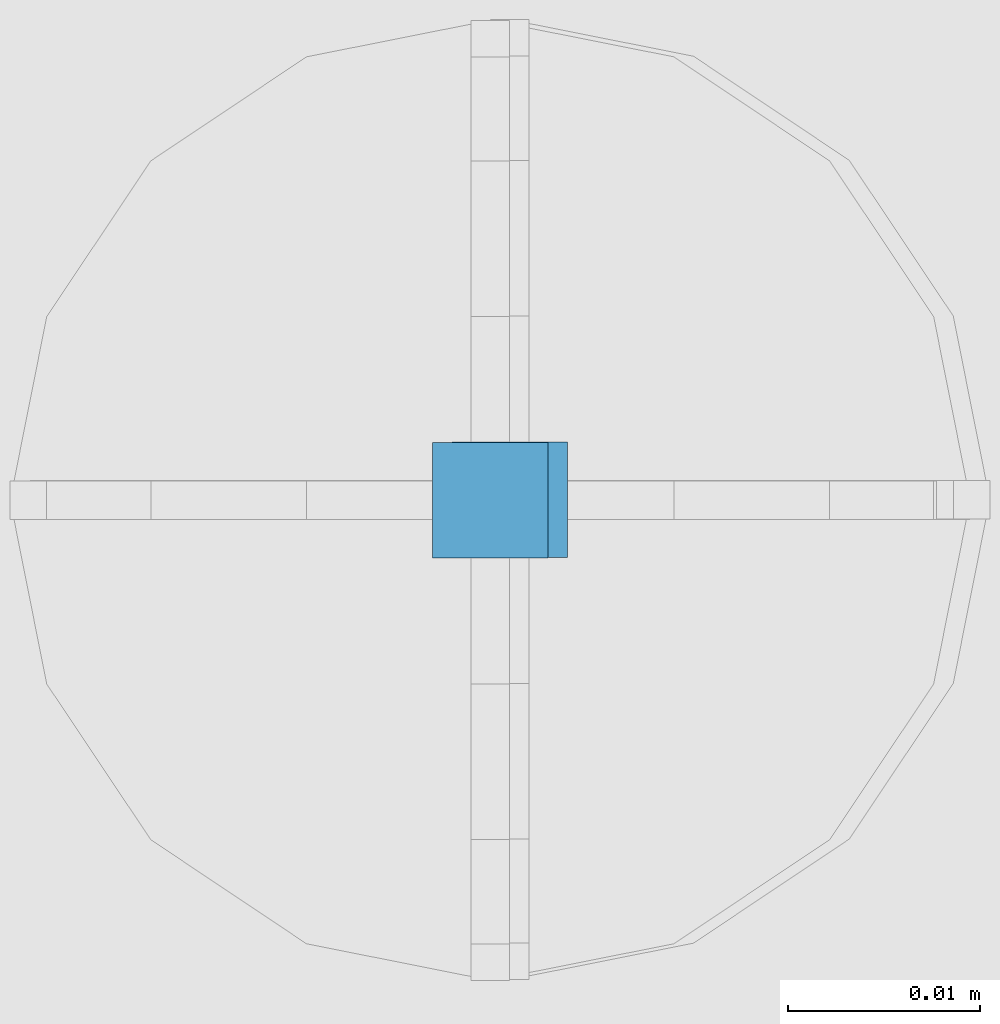
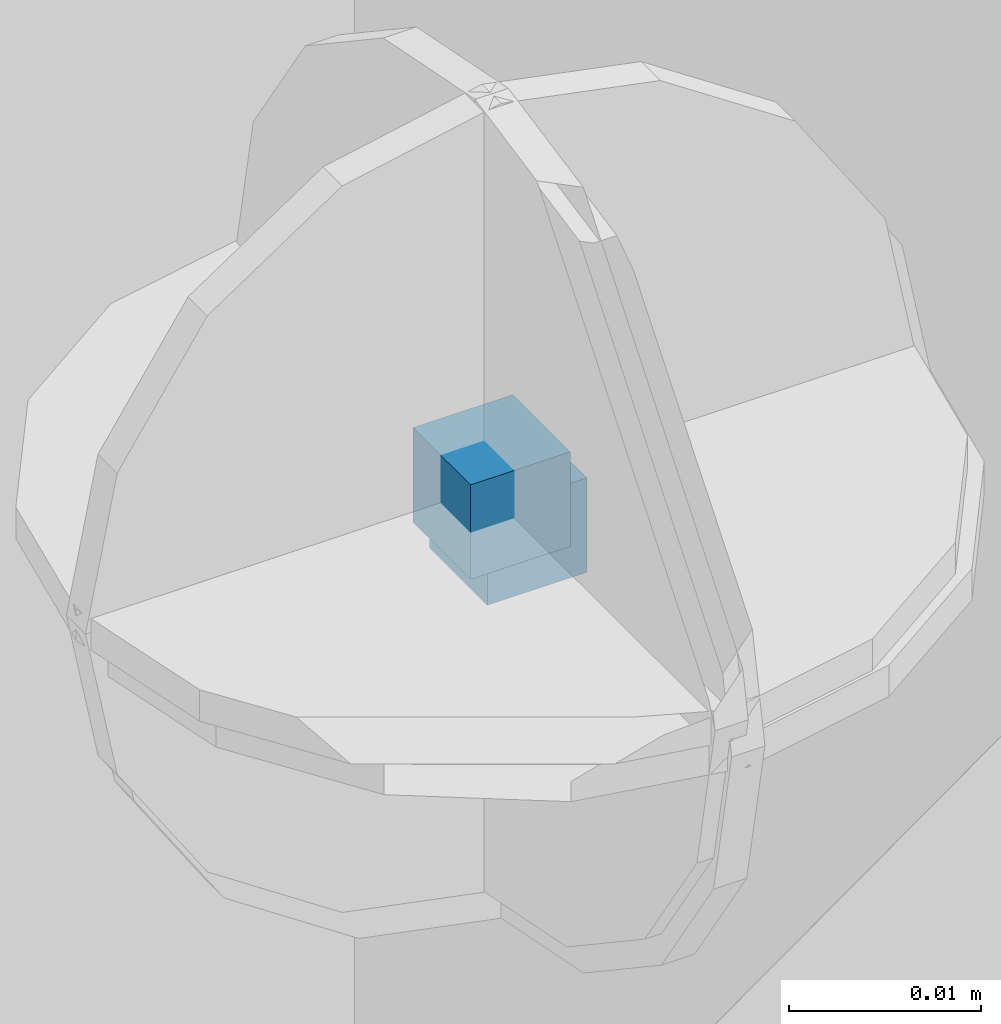
# One storey, part 73 of 341: 2 columns, 3 elements without a shape of their own.
"""IFC2X3 building model written with IfcOpenShell, lengths in millimetres."""

from ifc_helpers import new_model, si_unit, frame, origin_with_axes, place, context, subcontext, project, spatial, faceted_brep, material, type_object, element, aggregate, save


model = new_model("IFC2X3")

# Units and contexts
model_context = context("Model", 3, precision=1e-05, world=origin_with_axes())
body_context = subcontext(model_context, "Body", "Model", "MODEL_VIEW")
ifc_project = project(units=[si_unit("LENGTHUNIT", "METRE", prefix="MILLI"), si_unit("AREAUNIT", "SQUARE_METRE"), si_unit("VOLUMEUNIT", "CUBIC_METRE"), si_unit("MASSUNIT", "GRAM", prefix="KILO"), si_unit("TIMEUNIT", "SECOND"), si_unit("PLANEANGLEUNIT", "RADIAN"), si_unit("SOLIDANGLEUNIT", "STERADIAN"), si_unit("THERMODYNAMICTEMPERATUREUNIT", "DEGREE_CELSIUS"), si_unit("LUMINOUSINTENSITYUNIT", "LUMEN")], contexts=[model_context])

# Site, building, storey
site_placement = place(None, origin_with_axes())
site = spatial("IfcSite", under=ifc_project, at=site_placement, CompositionType="ELEMENT")
building_placement = place(site_placement, origin_with_axes())
building = spatial("IfcBuilding", under=site, at=building_placement, CompositionType="ELEMENT")
storey_placement = place(building_placement, origin_with_axes())
storey = spatial("IfcBuildingStorey", under=building, at=storey_placement, Name="5", CompositionType="ELEMENT", Elevation=0.0)

# Assemblies, columns
assembly_1_placement = place(storey_placement, origin_with_axes())
assembly_1 = element("IfcElementAssembly", 1, at=assembly_1_placement, inside=storey, AssemblyPlace="NOTDEFINED", PredefinedType="REINFORCEMENT_UNIT")
assembly_2_placement = place(assembly_1_placement, origin_with_axes())
assembly_2 = element("IfcElementAssembly", 2, at=assembly_2_placement, Name="Steel Assembly", AssemblyPlace="NOTDEFINED", PredefinedType="RIGID_FRAME")
ifc_material = material(Name="STEEL/Steel_Undefined")
column_type = type_object("IfcColumnType", PredefinedType="NOTDEFINED")
column_1_placement = place(assembly_2_placement, frame((19805.3672816511, 20613.5564077389, 96731.5262892386), z_axis=(0.0, -1.0, 0.0), x_axis=(0.0, 0.0, 1.0)))
column_1 = element("IfcColumn", 3, at=column_1_placement, type_object=column_type, material=ifc_material, Name="PP", context=body_context, shape_type="Brep", body=[
    faceted_brep([(0.0, 3.0, -3.0), (0.0, 2.99999999999636, 3.0), (6.0, 2.99999999999636, 3.0), (6.0, 3.0, -3.0), (0.0, -3.00000000000364, 3.0), (6.0, -3.00000000000364, 3.0), (0.0, -3.0, -3.0), (6.0, -3.0, -3.0)], [[[0, 1, 2, 3]], [[1, 4, 5, 2]], [[4, 6, 7, 5]], [[6, 0, 3, 7]], [[5, 7, 3, 2]], [[6, 4, 1, 0]]]),
])
aggregate(assembly_2, [column_1])
assembly_3_placement = place(assembly_1_placement, origin_with_axes())
assembly_3 = element("IfcElementAssembly", 4, at=assembly_3_placement, Name="Steel Assembly", AssemblyPlace="NOTDEFINED", PredefinedType="RIGID_FRAME")
aggregate(assembly_1, [assembly_2, assembly_3])
column_2_placement = place(assembly_3_placement, frame((19806.3888800542, 20613.5887932168, 96729.4935861413), z_axis=(0.0, -1.0, 0.0), x_axis=(0.0, 0.0, 1.0)))
column_2 = element("IfcColumn", 5, at=column_2_placement, type_object=column_type, material=ifc_material, Name="PP", context=body_context, shape_type="Brep", body=[
    faceted_brep([(0.0, 3.0, -3.0), (0.0, 2.99999999999636, 3.0), (6.0, 2.99999999999636, 3.0), (6.0, 3.0, -3.0), (0.0, -3.00000000000364, 3.0), (6.0, -3.00000000000364, 3.0), (0.0, -3.0, -3.0), (6.0, -3.0, -3.0)], [[[0, 1, 2, 3]], [[1, 4, 5, 2]], [[4, 6, 7, 5]], [[6, 0, 3, 7]], [[5, 7, 3, 2]], [[6, 4, 1, 0]]]),
])
aggregate(assembly_3, [column_2])

save(model, "model.ifc")
